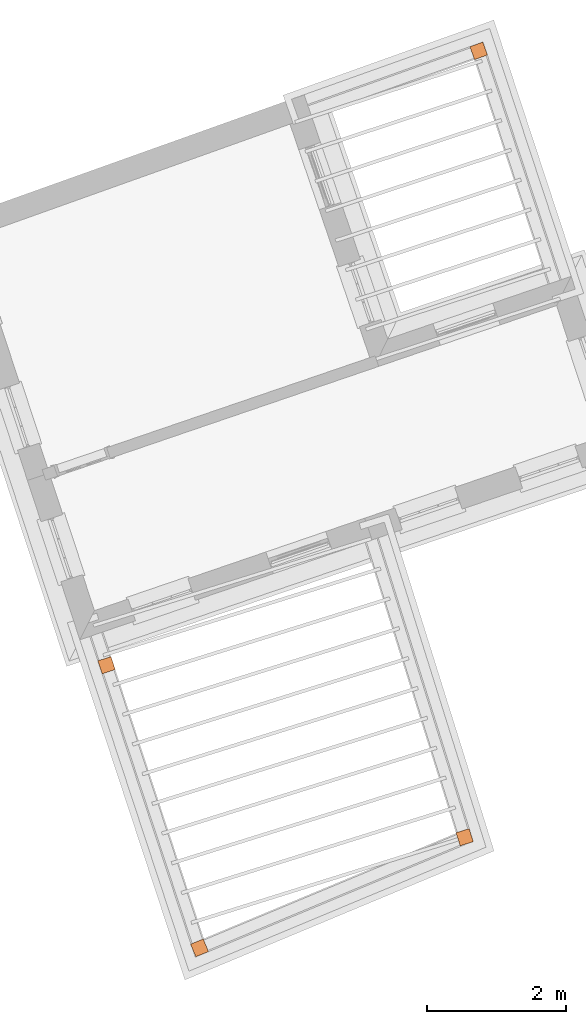
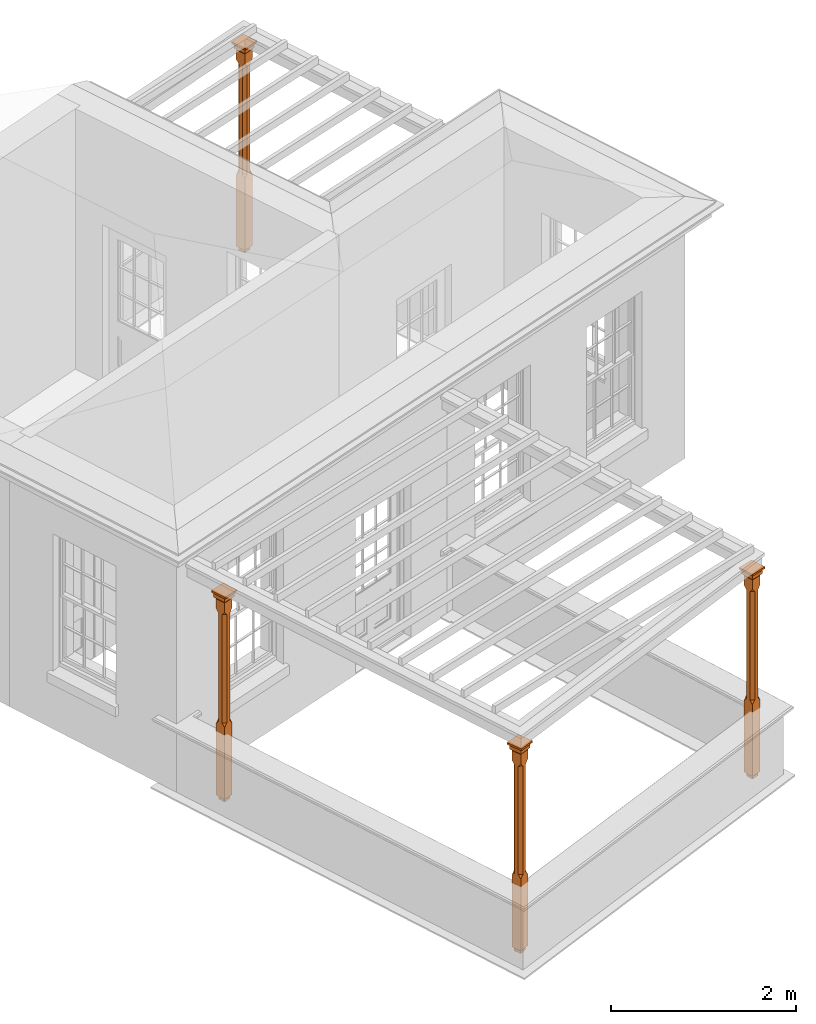
# One storey, part 10 of 10: 4 proxies.
"""IFC2X3 building model written with IfcOpenShell, lengths in metres."""

from ifc_helpers import new_model, si_unit, frame, origin, place, context, subcontext, project, spatial, faceted_brep, element, save


model = new_model("IFC2X3")

# Units and contexts
model_context = context("Model", 3, world=origin())
body_context = subcontext(model_context, "Body", "Model", "MODEL_VIEW")
ifc_project = project(units=[si_unit("PLANEANGLEUNIT", "RADIAN"), si_unit("MASSUNIT", "GRAM", prefix="KILO"), si_unit("FORCEUNIT", "NEWTON", prefix="KILO"), si_unit("LENGTHUNIT", "METRE")], contexts=[model_context])

# Site, building, storey
site_placement = place(None, origin())
site = spatial("IfcSite", under=ifc_project, at=site_placement, CompositionType="ELEMENT")
building_placement = place(None, origin())
building = spatial("IfcBuilding", under=site, at=building_placement, Name="Building plot-2", CompositionType="ELEMENT")
storey_placement = place(None, frame((0.0, 0.0, 8.2)))
storey = spatial("IfcBuildingStorey", under=building, at=storey_placement, Name="Floor 2", CompositionType="ELEMENT", Elevation=8.2)

# Proxies
proxy_1_placement = place(storey_placement, frame((34.9430056935765, 39.4767501459936, 0.0), z_axis=(0.0, 0.0, 1.0), x_axis=(-0.941791494157311, -0.336197533502166, 0.0)))
element("IfcBuildingElementProxy", 1, at=proxy_1_placement, inside=storey, Name="pergola post", CompositionType="ELEMENT", context=body_context, shape_type="Brep", held_by="IfcProductRepresentation", body=[
    faceted_brep([(0.0246, -0.0615, 2.47), (0.0615, -0.0246, 2.47), (0.0615, -0.0615, 2.516667), (0.0615, -0.0246, 1.044444), (0.0246, -0.0615, 1.044444), (0.0615, 0.0246, 2.47), (0.0615, 0.0615, 2.516667), (-0.0246, -0.0615, 2.47), (-0.0615, -0.0615, 2.516667), (-0.0246, -0.0615, 1.044444), (0.0615, -0.0615, 0.997778), (0.0615, 0.0246, 1.044444), (0.0246, 0.0615, 2.47), (0.0615, 0.0615, 2.641111), (0.0615, -0.0615, 2.641111), (-0.0615, -0.0615, 2.641111), (-0.0615, -0.0246, 2.47), (-0.0615, -0.0246, 1.044444), (-0.0615, -0.0615, 0.997778), (0.0615, 0.0615, 0.997778), (0.0246, 0.0615, 1.044444), (-0.0246, 0.0615, 2.47), (-0.0615, 0.0615, 2.516667), (0.04305, 0.04305, 2.641111), (0.04305, -0.04305, 2.641111), (-0.0615, 0.0615, 2.641111), (-0.04305, -0.04305, 2.641111), (-0.0615, 0.0246, 2.47), (-0.0615, 0.0246, 1.044444), (0.0615, -0.0615, 0.053333), (-0.0615, -0.0615, 0.053333), (0.0615, 0.0615, 0.053333), (-0.0246, 0.0615, 1.044444), (-0.04305, 0.04305, 2.641111), (0.04305, 0.04305, 2.664444), (0.04305, -0.04305, 2.664444), (-0.04305, -0.04305, 2.664444), (-0.0615, 0.0615, 0.997778), (-0.0615, 0.0615, 0.053333), (-0.04305, -0.04305, 0.053333), (0.04305, -0.04305, 0.053333), (0.04305, 0.04305, 0.053333), (-0.04305, 0.04305, 2.664444), (0.07995, 0.07995, 2.664444), (0.07995, -0.07995, 2.664444), (-0.07995, -0.07995, 2.664444), (-0.04305, 0.04305, 0.053333), (-0.04305, -0.04305, 0.0), (0.04305, -0.04305, 0.0), (0.04305, 0.04305, 0.0), (-0.07995, 0.07995, 2.664444), (0.07995, 0.07995, 2.726667), (0.07995, -0.07995, 2.726667), (-0.07995, -0.07995, 2.726667), (-0.04305, 0.04305, 0.0), (-0.07995, 0.07995, 2.726667), (0.0984, 0.0984, 2.726667), (0.0984, -0.0984, 2.726667), (-0.0984, -0.0984, 2.726667), (-0.0984, 0.0984, 2.726667), (0.0984, 0.0984, 2.75), (0.0984, -0.0984, 2.75), (-0.0984, -0.0984, 2.75), (-0.0984, 0.0984, 2.75)], [[[0, 1, 2]], [[3, 1, 0, 4]], [[1, 5, 6, 2]], [[7, 0, 2, 8]], [[4, 0, 7, 9]], [[3, 4, 10]], [[1, 3, 11, 5]], [[5, 12, 6]], [[13, 14, 2, 6]], [[15, 8, 2, 14]], [[8, 16, 7]], [[9, 7, 16, 17]], [[9, 18, 10, 4]], [[3, 10, 19, 11]], [[20, 12, 5, 11]], [[21, 22, 6, 12]], [[14, 13, 23, 24]], [[13, 6, 22, 25]], [[25, 22, 8, 15]], [[26, 15, 14, 24]], [[16, 8, 22, 27]], [[27, 28, 17, 16]], [[17, 18, 9]], [[29, 10, 18, 30]], [[31, 19, 10, 29]], [[20, 11, 19]], [[12, 20, 32, 21]], [[21, 27, 22]], [[33, 23, 13, 25]], [[23, 34, 35, 24]], [[26, 33, 25, 15]], [[36, 26, 24, 35]], [[28, 27, 21, 32]], [[17, 28, 37, 18]], [[38, 30, 18, 37]], [[29, 30, 39, 40]], [[31, 38, 37, 19]], [[40, 41, 31, 29]], [[32, 20, 19, 37]], [[33, 42, 34, 23]], [[43, 44, 35, 34]], [[42, 33, 26, 36]], [[36, 35, 44, 45]], [[28, 32, 37]], [[46, 39, 30, 38]], [[39, 47, 48, 40]], [[46, 38, 31, 41]], [[49, 41, 40, 48]], [[43, 34, 42, 50]], [[43, 51, 52, 44]], [[45, 50, 42, 36]], [[53, 45, 44, 52]], [[46, 54, 47, 39]], [[54, 46, 41, 49]], [[50, 55, 51, 43]], [[56, 57, 52, 51]], [[55, 50, 45, 53]], [[53, 52, 57, 58]], [[56, 51, 55, 59]], [[56, 60, 61, 57]], [[58, 59, 55, 53]], [[62, 58, 57, 61]], [[59, 63, 60, 56]], [[63, 62, 61, 60]], [[58, 62, 63, 59]], [[47, 54, 49, 48]]]),
])
proxy_2_placement = place(storey_placement, frame((29.5904846835731, 30.6402987287376, 0.0), z_axis=(0.0, 0.0, 1.0), x_axis=(0.312503451333649, -0.949916624185806, 0.0)))
element("IfcBuildingElementProxy", 2, at=proxy_2_placement, inside=storey, Name="pergola post", CompositionType="ELEMENT", context=body_context, shape_type="Brep", held_by="IfcProductRepresentation", body=[
    faceted_brep([(0.0246, -0.0615, 2.47), (0.0615, -0.0246, 2.47), (0.0615, -0.0615, 2.516667), (0.0615, -0.0246, 1.044444), (0.0246, -0.0615, 1.044444), (0.0615, 0.0246, 2.47), (0.0615, 0.0615, 2.516667), (-0.0246, -0.0615, 2.47), (-0.0615, -0.0615, 2.516667), (-0.0246, -0.0615, 1.044444), (0.0615, -0.0615, 0.997778), (0.0615, 0.0246, 1.044444), (0.0246, 0.0615, 2.47), (0.0615, 0.0615, 2.641111), (0.0615, -0.0615, 2.641111), (-0.0615, -0.0615, 2.641111), (-0.0615, -0.0246, 2.47), (-0.0615, -0.0246, 1.044444), (-0.0615, -0.0615, 0.997778), (0.0615, 0.0615, 0.997778), (0.0246, 0.0615, 1.044444), (-0.0246, 0.0615, 2.47), (-0.0615, 0.0615, 2.516667), (0.04305, 0.04305, 2.641111), (0.04305, -0.04305, 2.641111), (-0.0615, 0.0615, 2.641111), (-0.04305, -0.04305, 2.641111), (-0.0615, 0.0246, 2.47), (-0.0615, 0.0246, 1.044444), (0.0615, -0.0615, 0.053333), (-0.0615, -0.0615, 0.053333), (0.0615, 0.0615, 0.053333), (-0.0246, 0.0615, 1.044444), (-0.04305, 0.04305, 2.641111), (0.04305, 0.04305, 2.664444), (0.04305, -0.04305, 2.664444), (-0.04305, -0.04305, 2.664444), (-0.0615, 0.0615, 0.997778), (-0.0615, 0.0615, 0.053333), (-0.04305, -0.04305, 0.053333), (0.04305, -0.04305, 0.053333), (0.04305, 0.04305, 0.053333), (-0.04305, 0.04305, 2.664444), (0.07995, 0.07995, 2.664444), (0.07995, -0.07995, 2.664444), (-0.07995, -0.07995, 2.664444), (-0.04305, 0.04305, 0.053333), (-0.04305, -0.04305, 0.0), (0.04305, -0.04305, 0.0), (0.04305, 0.04305, 0.0), (-0.07995, 0.07995, 2.664444), (0.07995, 0.07995, 2.726667), (0.07995, -0.07995, 2.726667), (-0.07995, -0.07995, 2.726667), (-0.04305, 0.04305, 0.0), (-0.07995, 0.07995, 2.726667), (0.0984, 0.0984, 2.726667), (0.0984, -0.0984, 2.726667), (-0.0984, -0.0984, 2.726667), (-0.0984, 0.0984, 2.726667), (0.0984, 0.0984, 2.75), (0.0984, -0.0984, 2.75), (-0.0984, -0.0984, 2.75), (-0.0984, 0.0984, 2.75)], [[[0, 1, 2]], [[3, 1, 0, 4]], [[1, 5, 6, 2]], [[7, 0, 2, 8]], [[4, 0, 7, 9]], [[3, 4, 10]], [[1, 3, 11, 5]], [[5, 12, 6]], [[13, 14, 2, 6]], [[15, 8, 2, 14]], [[8, 16, 7]], [[9, 7, 16, 17]], [[9, 18, 10, 4]], [[3, 10, 19, 11]], [[20, 12, 5, 11]], [[21, 22, 6, 12]], [[14, 13, 23, 24]], [[13, 6, 22, 25]], [[25, 22, 8, 15]], [[26, 15, 14, 24]], [[16, 8, 22, 27]], [[27, 28, 17, 16]], [[17, 18, 9]], [[29, 10, 18, 30]], [[31, 19, 10, 29]], [[20, 11, 19]], [[12, 20, 32, 21]], [[21, 27, 22]], [[33, 23, 13, 25]], [[23, 34, 35, 24]], [[26, 33, 25, 15]], [[36, 26, 24, 35]], [[28, 27, 21, 32]], [[17, 28, 37, 18]], [[38, 30, 18, 37]], [[29, 30, 39, 40]], [[31, 38, 37, 19]], [[40, 41, 31, 29]], [[32, 20, 19, 37]], [[33, 42, 34, 23]], [[43, 44, 35, 34]], [[42, 33, 26, 36]], [[36, 35, 44, 45]], [[28, 32, 37]], [[46, 39, 30, 38]], [[39, 47, 48, 40]], [[46, 38, 31, 41]], [[49, 41, 40, 48]], [[43, 34, 42, 50]], [[43, 51, 52, 44]], [[45, 50, 42, 36]], [[53, 45, 44, 52]], [[46, 54, 47, 39]], [[54, 46, 41, 49]], [[50, 55, 51, 43]], [[56, 57, 52, 51]], [[55, 50, 45, 53]], [[53, 52, 57, 58]], [[56, 51, 55, 59]], [[56, 60, 61, 57]], [[58, 59, 55, 53]], [[62, 58, 57, 61]], [[59, 63, 60, 56]], [[63, 62, 61, 60]], [[58, 62, 63, 59]], [[47, 54, 49, 48]]]),
])
proxy_3_placement = place(storey_placement, frame((30.9280592094509, 26.5744739424948, 0.0), z_axis=(0.0, 0.0, 1.0), x_axis=(0.92288256613994, 0.385081509702763, 0.0)))
element("IfcBuildingElementProxy", 3, at=proxy_3_placement, inside=storey, Name="pergola post", CompositionType="ELEMENT", context=body_context, shape_type="Brep", held_by="IfcProductRepresentation", body=[
    faceted_brep([(0.0246, -0.0615, 2.47), (0.0615, -0.0246, 2.47), (0.0615, -0.0615, 2.516667), (0.0615, -0.0246, 1.044444), (0.0246, -0.0615, 1.044444), (0.0615, 0.0246, 2.47), (0.0615, 0.0615, 2.516667), (-0.0246, -0.0615, 2.47), (-0.0615, -0.0615, 2.516667), (-0.0246, -0.0615, 1.044444), (0.0615, -0.0615, 0.997778), (0.0615, 0.0246, 1.044444), (0.0246, 0.0615, 2.47), (0.0615, 0.0615, 2.641111), (0.0615, -0.0615, 2.641111), (-0.0615, -0.0615, 2.641111), (-0.0615, -0.0246, 2.47), (-0.0615, -0.0246, 1.044444), (-0.0615, -0.0615, 0.997778), (0.0615, 0.0615, 0.997778), (0.0246, 0.0615, 1.044444), (-0.0246, 0.0615, 2.47), (-0.0615, 0.0615, 2.516667), (0.04305, 0.04305, 2.641111), (0.04305, -0.04305, 2.641111), (-0.0615, 0.0615, 2.641111), (-0.04305, -0.04305, 2.641111), (-0.0615, 0.0246, 2.47), (-0.0615, 0.0246, 1.044444), (0.0615, -0.0615, 0.053333), (-0.0615, -0.0615, 0.053333), (0.0615, 0.0615, 0.053333), (-0.0246, 0.0615, 1.044444), (-0.04305, 0.04305, 2.641111), (0.04305, 0.04305, 2.664444), (0.04305, -0.04305, 2.664444), (-0.04305, -0.04305, 2.664444), (-0.0615, 0.0615, 0.997778), (-0.0615, 0.0615, 0.053333), (-0.04305, -0.04305, 0.053333), (0.04305, -0.04305, 0.053333), (0.04305, 0.04305, 0.053333), (-0.04305, 0.04305, 2.664444), (0.07995, 0.07995, 2.664444), (0.07995, -0.07995, 2.664444), (-0.07995, -0.07995, 2.664444), (-0.04305, 0.04305, 0.053333), (-0.04305, -0.04305, 0.0), (0.04305, -0.04305, 0.0), (0.04305, 0.04305, 0.0), (-0.07995, 0.07995, 2.664444), (0.07995, 0.07995, 2.726667), (0.07995, -0.07995, 2.726667), (-0.07995, -0.07995, 2.726667), (-0.04305, 0.04305, 0.0), (-0.07995, 0.07995, 2.726667), (0.0984, 0.0984, 2.726667), (0.0984, -0.0984, 2.726667), (-0.0984, -0.0984, 2.726667), (-0.0984, 0.0984, 2.726667), (0.0984, 0.0984, 2.75), (0.0984, -0.0984, 2.75), (-0.0984, -0.0984, 2.75), (-0.0984, 0.0984, 2.75)], [[[0, 1, 2]], [[3, 1, 0, 4]], [[1, 5, 6, 2]], [[7, 0, 2, 8]], [[4, 0, 7, 9]], [[3, 4, 10]], [[1, 3, 11, 5]], [[5, 12, 6]], [[13, 14, 2, 6]], [[15, 8, 2, 14]], [[8, 16, 7]], [[9, 7, 16, 17]], [[9, 18, 10, 4]], [[3, 10, 19, 11]], [[20, 12, 5, 11]], [[21, 22, 6, 12]], [[14, 13, 23, 24]], [[13, 6, 22, 25]], [[25, 22, 8, 15]], [[26, 15, 14, 24]], [[16, 8, 22, 27]], [[27, 28, 17, 16]], [[17, 18, 9]], [[29, 10, 18, 30]], [[31, 19, 10, 29]], [[20, 11, 19]], [[12, 20, 32, 21]], [[21, 27, 22]], [[33, 23, 13, 25]], [[23, 34, 35, 24]], [[26, 33, 25, 15]], [[36, 26, 24, 35]], [[28, 27, 21, 32]], [[17, 28, 37, 18]], [[38, 30, 18, 37]], [[29, 30, 39, 40]], [[31, 38, 37, 19]], [[40, 41, 31, 29]], [[32, 20, 19, 37]], [[33, 42, 34, 23]], [[43, 44, 35, 34]], [[42, 33, 26, 36]], [[36, 35, 44, 45]], [[28, 32, 37]], [[46, 39, 30, 38]], [[39, 47, 48, 40]], [[46, 38, 31, 41]], [[49, 41, 40, 48]], [[43, 34, 42, 50]], [[43, 51, 52, 44]], [[45, 50, 42, 36]], [[53, 45, 44, 52]], [[46, 54, 47, 39]], [[54, 46, 41, 49]], [[50, 55, 51, 43]], [[56, 57, 52, 51]], [[55, 50, 45, 53]], [[53, 52, 57, 58]], [[56, 51, 55, 59]], [[56, 60, 61, 57]], [[58, 59, 55, 53]], [[62, 58, 57, 61]], [[59, 63, 60, 56]], [[63, 62, 61, 60]], [[58, 62, 63, 59]], [[47, 54, 49, 48]]]),
])
proxy_4_placement = place(storey_placement, frame((34.7416099113103, 28.1657141668522, 0.0), z_axis=(0.0, 0.0, 1.0), x_axis=(-0.298599451959998, 0.954378524113566, 0.0)))
element("IfcBuildingElementProxy", 4, at=proxy_4_placement, inside=storey, Name="pergola post", CompositionType="ELEMENT", context=body_context, shape_type="Brep", held_by="IfcProductRepresentation", body=[
    faceted_brep([(0.0246, -0.0615, 2.47), (0.0615, -0.0246, 2.47), (0.0615, -0.0615, 2.516667), (0.0615, -0.0246, 1.044444), (0.0246, -0.0615, 1.044444), (0.0615, 0.0246, 2.47), (0.0615, 0.0615, 2.516667), (-0.0246, -0.0615, 2.47), (-0.0615, -0.0615, 2.516667), (-0.0246, -0.0615, 1.044444), (0.0615, -0.0615, 0.997778), (0.0615, 0.0246, 1.044444), (0.0246, 0.0615, 2.47), (0.0615, 0.0615, 2.641111), (0.0615, -0.0615, 2.641111), (-0.0615, -0.0615, 2.641111), (-0.0615, -0.0246, 2.47), (-0.0615, -0.0246, 1.044444), (-0.0615, -0.0615, 0.997778), (0.0615, 0.0615, 0.997778), (0.0246, 0.0615, 1.044444), (-0.0246, 0.0615, 2.47), (-0.0615, 0.0615, 2.516667), (0.04305, 0.04305, 2.641111), (0.04305, -0.04305, 2.641111), (-0.0615, 0.0615, 2.641111), (-0.04305, -0.04305, 2.641111), (-0.0615, 0.0246, 2.47), (-0.0615, 0.0246, 1.044444), (0.0615, -0.0615, 0.053333), (-0.0615, -0.0615, 0.053333), (0.0615, 0.0615, 0.053333), (-0.0246, 0.0615, 1.044444), (-0.04305, 0.04305, 2.641111), (0.04305, 0.04305, 2.664444), (0.04305, -0.04305, 2.664444), (-0.04305, -0.04305, 2.664444), (-0.0615, 0.0615, 0.997778), (-0.0615, 0.0615, 0.053333), (-0.04305, -0.04305, 0.053333), (0.04305, -0.04305, 0.053333), (0.04305, 0.04305, 0.053333), (-0.04305, 0.04305, 2.664444), (0.07995, 0.07995, 2.664444), (0.07995, -0.07995, 2.664444), (-0.07995, -0.07995, 2.664444), (-0.04305, 0.04305, 0.053333), (-0.04305, -0.04305, 0.0), (0.04305, -0.04305, 0.0), (0.04305, 0.04305, 0.0), (-0.07995, 0.07995, 2.664444), (0.07995, 0.07995, 2.726667), (0.07995, -0.07995, 2.726667), (-0.07995, -0.07995, 2.726667), (-0.04305, 0.04305, 0.0), (-0.07995, 0.07995, 2.726667), (0.0984, 0.0984, 2.726667), (0.0984, -0.0984, 2.726667), (-0.0984, -0.0984, 2.726667), (-0.0984, 0.0984, 2.726667), (0.0984, 0.0984, 2.75), (0.0984, -0.0984, 2.75), (-0.0984, -0.0984, 2.75), (-0.0984, 0.0984, 2.75)], [[[0, 1, 2]], [[3, 1, 0, 4]], [[1, 5, 6, 2]], [[7, 0, 2, 8]], [[4, 0, 7, 9]], [[3, 4, 10]], [[1, 3, 11, 5]], [[5, 12, 6]], [[13, 14, 2, 6]], [[15, 8, 2, 14]], [[8, 16, 7]], [[9, 7, 16, 17]], [[9, 18, 10, 4]], [[3, 10, 19, 11]], [[20, 12, 5, 11]], [[21, 22, 6, 12]], [[14, 13, 23, 24]], [[13, 6, 22, 25]], [[25, 22, 8, 15]], [[26, 15, 14, 24]], [[16, 8, 22, 27]], [[27, 28, 17, 16]], [[17, 18, 9]], [[29, 10, 18, 30]], [[31, 19, 10, 29]], [[20, 11, 19]], [[12, 20, 32, 21]], [[21, 27, 22]], [[33, 23, 13, 25]], [[23, 34, 35, 24]], [[26, 33, 25, 15]], [[36, 26, 24, 35]], [[28, 27, 21, 32]], [[17, 28, 37, 18]], [[38, 30, 18, 37]], [[29, 30, 39, 40]], [[31, 38, 37, 19]], [[40, 41, 31, 29]], [[32, 20, 19, 37]], [[33, 42, 34, 23]], [[43, 44, 35, 34]], [[42, 33, 26, 36]], [[36, 35, 44, 45]], [[28, 32, 37]], [[46, 39, 30, 38]], [[39, 47, 48, 40]], [[46, 38, 31, 41]], [[49, 41, 40, 48]], [[43, 34, 42, 50]], [[43, 51, 52, 44]], [[45, 50, 42, 36]], [[53, 45, 44, 52]], [[46, 54, 47, 39]], [[54, 46, 41, 49]], [[50, 55, 51, 43]], [[56, 57, 52, 51]], [[55, 50, 45, 53]], [[53, 52, 57, 58]], [[56, 51, 55, 59]], [[56, 60, 61, 57]], [[58, 59, 55, 53]], [[62, 58, 57, 61]], [[59, 63, 60, 56]], [[63, 62, 61, 60]], [[58, 62, 63, 59]], [[47, 54, 49, 48]]]),
])

save(model, "model.ifc")
